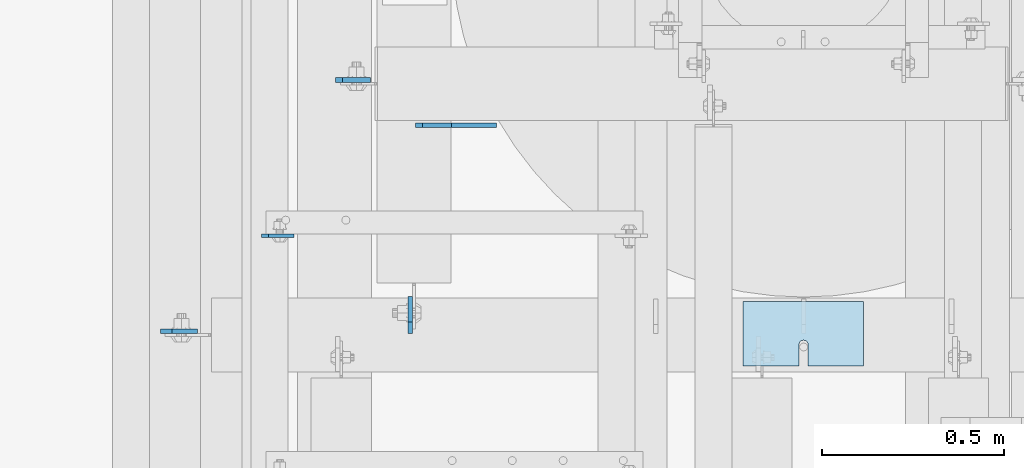
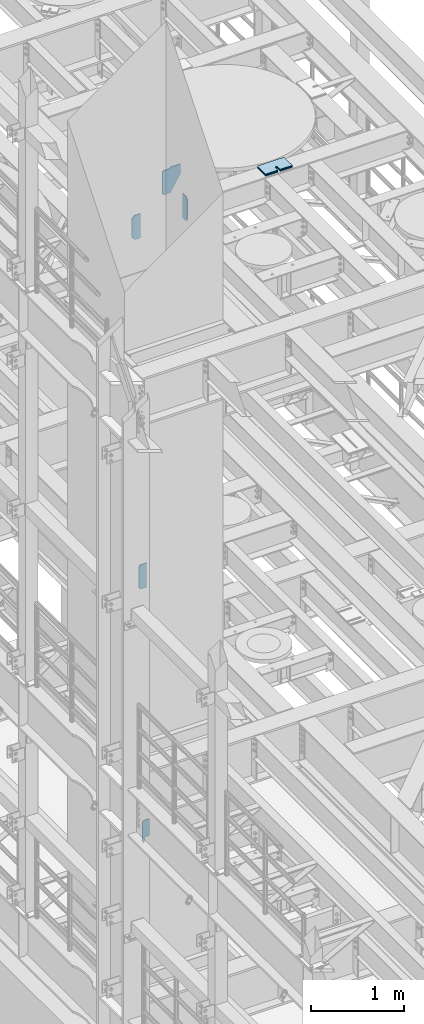
# One storey, part 1626 of 1876: 11 plates, 11 elements without a shape of their own.
"""IFC2X3 building model written with IfcOpenShell, lengths in millimetres."""

from ifc_helpers import new_model, si_unit, frame, origin_with_axes, place, context, subcontext, project, spatial, faceted_brep, material, type_object, element, aggregate, save


model = new_model("IFC2X3")

# Units and contexts
model_context = context("Model", 3, precision=1e-05, world=origin_with_axes())
body_context = subcontext(model_context, "Body", "Model", "MODEL_VIEW")
ifc_project = project(units=[si_unit("LENGTHUNIT", "METRE", prefix="MILLI"), si_unit("AREAUNIT", "SQUARE_METRE"), si_unit("VOLUMEUNIT", "CUBIC_METRE"), si_unit("MASSUNIT", "GRAM", prefix="KILO"), si_unit("TIMEUNIT", "SECOND"), si_unit("PLANEANGLEUNIT", "RADIAN"), si_unit("SOLIDANGLEUNIT", "STERADIAN"), si_unit("THERMODYNAMICTEMPERATUREUNIT", "DEGREE_CELSIUS"), si_unit("LUMINOUSINTENSITYUNIT", "LUMEN")], contexts=[model_context])

# Site, building, storey
site_placement = place(None, origin_with_axes())
site = spatial("IfcSite", under=ifc_project, at=site_placement, CompositionType="ELEMENT")
building_placement = place(site_placement, origin_with_axes())
building = spatial("IfcBuilding", under=site, at=building_placement, Name="Undefined", CompositionType="ELEMENT")
storey_placement = place(building_placement, origin_with_axes())
storey = spatial("IfcBuildingStorey", under=building, at=storey_placement, Name="Undefined", CompositionType="ELEMENT", Elevation=0.0)

# Assembly, plate
assembly_1_placement = place(storey_placement, origin_with_axes())
assembly_1 = element("IfcElementAssembly", 1, at=assembly_1_placement, inside=storey, Name="BEAM", AssemblyPlace="NOTDEFINED", PredefinedType="RIGID_FRAME")
ifc_material = material(Name="STEEL/A36")
plate_type_1 = type_object("IfcPlateType", PredefinedType="NOTDEFINED")
plate_1_placement = place(assembly_1_placement, frame((1882.775, 4376.73659114838, 4833.9375), z_axis=(0.0, 0.0, 1.0), x_axis=(1.0, 0.0, 0.0)))
plate_1 = element("IfcPlate", 2, at=plate_1_placement, type_object=plate_type_1, material=ifc_material, Name="PLATE", context=body_context, shape_type="Brep", body=[
    faceted_brep([(30.5410794447303, -4.76249999999982, 0.0), (30.5448681471291, 4.76249999999982, 0.0), (30.5448681471253, 4.76249999999982, 58.7375017166132), (30.5410794447266, -4.76249999999982, 58.7375017166132), (31.5115981461893, 4.76249999999982, 63.5975812346587), (31.5078094437904, -4.76249999999982, 63.5975812346587), (34.264612264453, 4.76249999999982, 67.7177577028133), (34.2608235620542, -4.76249999999982, 67.7177577028133), (38.3847890585462, 4.76249999999982, 70.4707716032917), (38.3810003561475, -4.76249999999982, 70.4707716032917), (43.2448689610637, 4.76249999999982, 71.4375015258793), (43.2410802586651, -4.76249999999982, 71.4375015258793), (88.8981053933326, -4.76249924578678, 71.4375015258793), (88.9000015258789, 4.76250000000005, 71.4375), (19.0499992370605, -4.76249999999982, 0.0), (0.0, -4.76249999999982, 19.0499992370605), (0.0, 4.76249999999982, 19.0499992370605), (19.0499992370605, 4.76249999999982, 0.0), (0.0, -4.76249999999982, 271.462512969971), (0.0, 4.76249999999982, 271.462512969971), (19.0499992370605, -4.76249999999982, 290.512512207031), (19.0499992370605, 4.76249999999982, 290.512512207031), (88.9000015258789, -4.76249999999982, 290.512512207031), (88.9000015258789, 4.76249999999982, 290.512512207031)], [[[0, 1, 2, 3]], [[3, 2, 4, 5]], [[5, 4, 6, 7]], [[7, 6, 8, 9]], [[9, 8, 10, 11]], [[12, 11, 10, 13]], [[14, 15, 16, 17]], [[15, 18, 19, 16]], [[18, 20, 21, 19]], [[20, 22, 23, 21]], [[23, 22, 12, 13]], [[8, 6, 4, 2, 1, 17, 16, 19, 21, 23, 13, 10]], [[14, 17, 1, 0]], [[22, 20, 18, 15, 14, 0, 3, 5, 7, 9, 11, 12]]]),
])
aggregate(assembly_1, [plate_1])

assembly_2_placement = place(storey_placement, origin_with_axes())
assembly_2 = element("IfcElementAssembly", 3, at=assembly_2_placement, inside=storey, Name="BEAM", AssemblyPlace="NOTDEFINED", PredefinedType="RIGID_FRAME")
plate_type_2 = type_object("IfcPlateType", PredefinedType="NOTDEFINED")
plate_2_placement = place(assembly_2_placement, frame((2086.76875, 4804.56875009537, 7821.6125), z_axis=(0.0, 0.0, 1.0), x_axis=(1.0, 0.0, 0.0)))
plate_2 = element("IfcPlate", 4, at=plate_2_placement, type_object=plate_type_2, material=ifc_material, Name="PLATE", context=body_context, shape_type="Brep", body=[
    faceted_brep([(0.0, -6.35000000000196, 19.0499992370605), (-9.09494701772928e-13, -6.34999999999764, 296.862506866455), (1.81898940354586e-12, 6.34999999999786, 296.862506866455), (0.0, 6.35000000000105, 19.0499992370605), (19.0499992370587, -6.34999999999604, 315.912506103516), (19.0499992370624, 6.34999999999945, 315.912506103516), (95.25, -6.35000000000036, 315.912506103516), (95.25, 6.35000000000036, 315.912506103516), (95.25, -6.35000000000036, 0.0), (95.25, 6.35000000000036, 0.0), (19.0499992370642, -6.35000000000105, 0.0), (19.0499992370633, 6.35000000000105, 0.0)], [[[0, 1, 2, 3]], [[1, 4, 5, 2]], [[4, 6, 7, 5]], [[6, 8, 9, 7]], [[8, 10, 11, 9]], [[10, 0, 3, 11]], [[5, 7, 9, 11, 3, 2]], [[10, 8, 6, 4, 1, 0]]]),
])
aggregate(assembly_2, [plate_2])

assembly_3_placement = place(storey_placement, origin_with_axes())
assembly_3 = element("IfcElementAssembly", 5, at=assembly_3_placement, inside=storey, Name="BEAM", AssemblyPlace="NOTDEFINED", PredefinedType="RIGID_FRAME")
plate_type_3 = type_object("IfcPlateType", PredefinedType="NOTDEFINED")
plate_3_placement = place(assembly_3_placement, frame((1605.75625, 4114.00625009537, 12974.6375), z_axis=(0.0, 0.0, 1.0), x_axis=(1.0, 0.0, 0.0)))
plate_3 = element("IfcPlate", 6, at=plate_3_placement, type_object=plate_type_3, material=ifc_material, Name="PLATE", context=body_context, shape_type="Brep", body=[
    faceted_brep([(0.0, -6.34999999999991, 31.75), (-1.81898940354586e-12, -6.34999999999991, 284.162506103516), (1.81898940354586e-12, 6.35000000000173, 284.162506103516), (0.0, 6.34999999999991, 31.75), (31.7499999999927, -6.34999999999991, 315.912506103516), (31.7499999999982, 6.35000000000309, 315.912506103516), (101.599998474121, -6.35000000000036, 315.912506103516), (101.599998474121, 6.35000000000036, 315.912506103516), (101.599998474121, -6.35000000000036, 0.0), (101.599998474121, 6.35000000000036, 0.0), (31.75, -6.34999999999991, 0.0), (31.75, 6.34999999999991, 0.0)], [[[0, 1, 2, 3]], [[1, 4, 5, 2]], [[4, 6, 7, 5]], [[6, 8, 9, 7]], [[8, 10, 11, 9]], [[10, 0, 3, 11]], [[5, 7, 9, 11, 3, 2]], [[10, 8, 6, 4, 1, 0]]]),
])
aggregate(assembly_3, [plate_3])

assembly_4_placement = place(storey_placement, origin_with_axes())
assembly_4 = element("IfcElementAssembly", 7, at=assembly_4_placement, inside=storey, Name="BEAM", AssemblyPlace="NOTDEFINED", PredefinedType="RIGID_FRAME")
plate_4_placement = place(assembly_4_placement, frame((2291.55624990463, 4107.65625, 12977.8125), z_axis=(0.0, 0.0, 1.0), x_axis=(0.0, 1.0, 0.0)))
plate_4 = element("IfcPlate", 8, at=plate_4_placement, type_object=plate_type_3, material=ifc_material, Name="PLATE", context=body_context, shape_type="Brep", body=[
    faceted_brep([(0.0, -6.34999999999991, 31.75), (-1.81898940354586e-12, -6.34999999999991, 284.162506103516), (1.81898940354586e-12, 6.35000000000173, 284.162506103516), (0.0, 6.34999999999991, 31.75), (31.7499999999927, -6.34999999999991, 315.912506103516), (31.7499999999982, 6.35000000000309, 315.912506103516), (101.599998474121, -6.35000000000036, 315.912506103516), (101.599998474121, 6.35000000000036, 315.912506103516), (101.599998474121, -6.35000000000036, 0.0), (101.599998474121, 6.35000000000036, 0.0), (31.75, -6.34999999999991, 0.0), (31.75, 6.34999999999991, 0.0)], [[[0, 1, 2, 3]], [[1, 4, 5, 2]], [[4, 6, 7, 5]], [[6, 8, 9, 7]], [[8, 10, 11, 9]], [[10, 0, 3, 11]], [[5, 7, 9, 11, 3, 2]], [[10, 8, 6, 4, 1, 0]]]),
])
aggregate(assembly_4, [plate_4])

assembly_5_placement = place(storey_placement, origin_with_axes())
assembly_5 = element("IfcElementAssembly", 9, at=assembly_5_placement, inside=storey, Name="SHIM PLATE", AssemblyPlace="NOTDEFINED", PredefinedType="RIGID_FRAME")
plate_type_4 = type_object("IfcPlateType", PredefinedType="NOTDEFINED")
plate_5_placement = place(assembly_5_placement, frame((3205.99836578369, 4196.45223303297, 13335.7925), z_axis=(1.0, 0.0, 0.0), x_axis=(0.0, -1.0, 0.0)))
plate_5 = element("IfcPlate", 10, at=plate_5_placement, type_object=plate_type_4, material=ifc_material, Name="SHIM PLATE", context=body_context, shape_type="Brep", body=[
    faceted_brep([(177.654449462891, -0.793499999999767, 153.152024232435), (177.654449462891, 0.793499999999767, 153.152024232435), (118.915740966797, 0.793499999999767, 153.152024232435), (118.915740966797, -0.793499999999767, 153.152024232435), (112.565739046814, 0.793499999999767, 154.853499989362), (112.565739046814, -0.793499999999767, 154.853499989362), (107.917214530273, 0.793499999999767, 159.502022760557), (107.917214530273, -0.793499999999767, 159.502022760557), (106.21573638916, 0.793499999999767, 165.8520240417), (106.21573638916, -0.793499999999767, 165.8520240417), (107.917214530273, 0.793499999999767, 172.202025322844), (107.917214530273, -0.793499999999767, 172.202025322844), (112.565739046813, 0.793499999999767, 176.850548094039), (112.565739046813, -0.793499999999767, 176.850548094039), (118.915740966797, 0.793499999999767, 178.552023850965), (118.915740966797, -0.793499999999767, 178.552023850965), (177.654449462891, -0.793499999999767, 178.552023850965), (177.654449462891, 0.793499999999767, 178.552023850965), (177.654449462891, -0.793499999999767, 0.0), (9.09494701772928e-13, -0.793499999999767, 0.0), (9.09494701772928e-13, 0.793499999999767, 0.0), (177.654449462891, 0.793499999999767, 0.0), (0.0, -0.793499999999767, 330.201965332031), (0.0, 0.793499999999767, 330.201965332031), (177.654449462891, -0.793499999999767, 330.201965332031), (177.654449462891, 0.793499999999767, 330.201965332031)], [[[0, 1, 2, 3]], [[3, 2, 4, 5]], [[5, 4, 6, 7]], [[7, 6, 8, 9]], [[9, 8, 10, 11]], [[11, 10, 12, 13]], [[13, 12, 14, 15]], [[16, 15, 14, 17]], [[18, 19, 20, 21]], [[19, 22, 23, 20]], [[22, 24, 25, 23]], [[25, 24, 16, 17]], [[12, 10, 8, 6, 4, 2, 1, 21, 20, 23, 25, 17, 14]], [[18, 21, 1, 0]], [[24, 22, 19, 18, 0, 3, 5, 7, 9, 11, 13, 15, 16]]]),
])
aggregate(assembly_5, [plate_5])

assembly_6_placement = place(storey_placement, origin_with_axes())
assembly_6 = element("IfcElementAssembly", 11, at=assembly_6_placement, inside=storey, Name="SHIM PLATE", AssemblyPlace="NOTDEFINED", PredefinedType="RIGID_FRAME")
plate_type_5 = type_object("IfcPlateType", PredefinedType="NOTDEFINED")
plate_6_placement = place(assembly_6_placement, frame((3205.99836578369, 4196.45223303297, 13333.4115), z_axis=(1.0, 0.0, 0.0), x_axis=(0.0, -1.0, 0.0)))
plate_6 = element("IfcPlate", 12, at=plate_6_placement, type_object=plate_type_5, material=ifc_material, Name="SHIM PLATE", context=body_context, shape_type="Brep", body=[
    faceted_brep([(177.654449462891, -1.58749999999964, 153.152024232435), (177.654449462891, 1.58749999999964, 153.152024232435), (118.915740966797, 1.58749999999964, 153.152024232435), (118.915740966797, -1.58749999999964, 153.152024232435), (112.565739046814, 1.58749999999964, 154.853499989362), (112.565739046814, -1.58749999999964, 154.853499989362), (107.917214530273, 1.58749999999964, 159.502022760557), (107.917214530273, -1.58749999999964, 159.502022760557), (106.21573638916, 1.58749999999964, 165.8520240417), (106.21573638916, -1.58749999999964, 165.8520240417), (107.917214530273, 1.58749999999964, 172.202025322844), (107.917214530273, -1.58749999999964, 172.202025322844), (112.565739046813, 1.58749999999964, 176.850548094039), (112.565739046813, -1.58749999999964, 176.850548094039), (118.915740966797, 1.58749999999964, 178.552023850965), (118.915740966797, -1.58749999999964, 178.552023850965), (177.654449462891, -1.58749999999964, 178.552023850965), (177.654449462891, 1.58749999999964, 178.552023850965), (177.654449462891, -1.58749999999964, 0.0), (9.09494701772928e-13, -1.58750000000146, 4.54747350886464e-13), (9.09494701772928e-13, 1.58750000000146, 4.54747350886464e-13), (177.654449462891, 1.58749999999964, 0.0), (0.0, -1.58749999999964, 330.201965332031), (0.0, 1.58749999999964, 330.201965332031), (177.654449462891, -1.58749999999964, 330.201965332031), (177.654449462891, 1.58749999999964, 330.201965332031)], [[[0, 1, 2, 3]], [[3, 2, 4, 5]], [[5, 4, 6, 7]], [[7, 6, 8, 9]], [[9, 8, 10, 11]], [[11, 10, 12, 13]], [[13, 12, 14, 15]], [[16, 15, 14, 17]], [[18, 19, 20, 21]], [[19, 22, 23, 20]], [[22, 24, 25, 23]], [[25, 24, 16, 17]], [[12, 10, 8, 6, 4, 2, 1, 21, 20, 23, 25, 17, 14]], [[18, 21, 1, 0]], [[24, 22, 19, 18, 0, 3, 5, 7, 9, 11, 13, 15, 16]]]),
])
aggregate(assembly_6, [plate_6])

assembly_7_placement = place(storey_placement, origin_with_axes())
assembly_7 = element("IfcElementAssembly", 13, at=assembly_7_placement, inside=storey, Name="SHIM PLATE", AssemblyPlace="NOTDEFINED", PredefinedType="RIGID_FRAME")
plate_7_placement = place(assembly_7_placement, frame((3205.99836578369, 4196.45223303297, 13330.2365), z_axis=(1.0, 0.0, 0.0), x_axis=(0.0, -1.0, 0.0)))
plate_7 = element("IfcPlate", 14, at=plate_7_placement, type_object=plate_type_5, material=ifc_material, Name="SHIM PLATE", context=body_context, shape_type="Brep", body=[
    faceted_brep([(177.654449462891, -1.58749999999964, 153.152024232435), (177.654449462891, 1.58749999999964, 153.152024232435), (118.915740966797, 1.58749999999964, 153.152024232435), (118.915740966797, -1.58749999999964, 153.152024232435), (112.565739046814, 1.58749999999964, 154.853499989362), (112.565739046814, -1.58749999999964, 154.853499989362), (107.917214530273, 1.58749999999964, 159.502022760557), (107.917214530273, -1.58749999999964, 159.502022760557), (106.21573638916, 1.58749999999964, 165.8520240417), (106.21573638916, -1.58749999999964, 165.8520240417), (107.917214530273, 1.58749999999964, 172.202025322844), (107.917214530273, -1.58749999999964, 172.202025322844), (112.565739046813, 1.58749999999964, 176.850548094039), (112.565739046813, -1.58749999999964, 176.850548094039), (118.915740966797, 1.58749999999964, 178.552023850965), (118.915740966797, -1.58749999999964, 178.552023850965), (177.654449462891, -1.58749999999964, 178.552023850965), (177.654449462891, 1.58749999999964, 178.552023850965), (177.654449462891, -1.58749999999964, 0.0), (9.09494701772928e-13, -1.58750000000146, 4.54747350886464e-13), (9.09494701772928e-13, 1.58750000000146, 4.54747350886464e-13), (177.654449462891, 1.58749999999964, 0.0), (0.0, -1.58749999999964, 330.201965332031), (0.0, 1.58749999999964, 330.201965332031), (177.654449462891, -1.58749999999964, 330.201965332031), (177.654449462891, 1.58749999999964, 330.201965332031)], [[[0, 1, 2, 3]], [[3, 2, 4, 5]], [[5, 4, 6, 7]], [[7, 6, 8, 9]], [[9, 8, 10, 11]], [[11, 10, 12, 13]], [[13, 12, 14, 15]], [[16, 15, 14, 17]], [[18, 19, 20, 21]], [[19, 22, 23, 20]], [[22, 24, 25, 23]], [[25, 24, 16, 17]], [[12, 10, 8, 6, 4, 2, 1, 21, 20, 23, 25, 17, 14]], [[18, 21, 1, 0]], [[24, 22, 19, 18, 0, 3, 5, 7, 9, 11, 13, 15, 16]]]),
])
aggregate(assembly_7, [plate_7])

assembly_8_placement = place(storey_placement, origin_with_axes())
assembly_8 = element("IfcElementAssembly", 15, at=assembly_8_placement, inside=storey, Name="SHIM PLATE", AssemblyPlace="NOTDEFINED", PredefinedType="RIGID_FRAME")
plate_type_6 = type_object("IfcPlateType", PredefinedType="NOTDEFINED")
plate_8_placement = place(assembly_8_placement, frame((3205.99836578369, 4196.45223303297, 13326.268), z_axis=(1.0, 0.0, 0.0), x_axis=(0.0, -1.0, 0.0)))
plate_8 = element("IfcPlate", 16, at=plate_8_placement, type_object=plate_type_6, material=ifc_material, Name="SHIM PLATE", context=body_context, shape_type="Brep", body=[
    faceted_brep([(177.654449462891, -2.3809999999994, 153.152024232435), (177.654449462891, 2.3809999999994, 153.152024232435), (118.915740966797, 2.3809999999994, 153.152024232435), (118.915740966797, -2.3809999999994, 153.152024232435), (112.565739046814, 2.3809999999994, 154.853499989362), (112.565739046814, -2.3809999999994, 154.853499989362), (107.917214530273, 2.3809999999994, 159.502022760557), (107.917214530273, -2.3809999999994, 159.502022760557), (106.21573638916, 2.3809999999994, 165.8520240417), (106.21573638916, -2.3809999999994, 165.8520240417), (107.917214530273, 2.3809999999994, 172.202025322844), (107.917214530273, -2.3809999999994, 172.202025322844), (112.565739046813, 2.3809999999994, 176.850548094039), (112.565739046813, -2.3809999999994, 176.850548094039), (118.915740966797, 2.3809999999994, 178.552023850965), (118.915740966797, -2.3809999999994, 178.552023850965), (177.654449462891, -2.3809999999994, 178.552023850965), (177.654449462891, 2.3809999999994, 178.552023850965), (177.654449462891, -2.3809999999994, 0.0), (0.0, -2.38100000000122, 4.54747350886464e-13), (0.0, 2.38100000000122, 4.54747350886464e-13), (177.654449462891, 2.3809999999994, 0.0), (0.0, -2.3809999999994, 330.201965332031), (0.0, 2.3809999999994, 330.201965332031), (177.654449462891, -2.3809999999994, 330.201965332031), (177.654449462891, 2.3809999999994, 330.201965332031)], [[[0, 1, 2, 3]], [[3, 2, 4, 5]], [[5, 4, 6, 7]], [[7, 6, 8, 9]], [[9, 8, 10, 11]], [[11, 10, 12, 13]], [[13, 12, 14, 15]], [[16, 15, 14, 17]], [[18, 19, 20, 21]], [[19, 22, 23, 20]], [[22, 24, 25, 23]], [[25, 24, 16, 17]], [[12, 10, 8, 6, 4, 2, 1, 21, 20, 23, 25, 17, 14]], [[18, 21, 1, 0]], [[24, 22, 19, 18, 0, 3, 5, 7, 9, 11, 13, 15, 16]]]),
])
aggregate(assembly_8, [plate_8])

assembly_9_placement = place(storey_placement, origin_with_axes())
assembly_9 = element("IfcElementAssembly", 17, at=assembly_9_placement, inside=storey, Name="SHIM PLATE", AssemblyPlace="NOTDEFINED", PredefinedType="RIGID_FRAME")
plate_9_placement = place(assembly_9_placement, frame((3205.99836578369, 4196.45223303297, 13321.506), z_axis=(1.0, 0.0, 0.0), x_axis=(0.0, -1.0, 0.0)))
plate_9 = element("IfcPlate", 18, at=plate_9_placement, type_object=plate_type_6, material=ifc_material, Name="SHIM PLATE", context=body_context, shape_type="Brep", body=[
    faceted_brep([(177.654449462891, -2.3809999999994, 153.152024232435), (177.654449462891, 2.3809999999994, 153.152024232435), (118.915740966797, 2.3809999999994, 153.152024232435), (118.915740966797, -2.3809999999994, 153.152024232435), (112.565739046814, 2.3809999999994, 154.853499989362), (112.565739046814, -2.3809999999994, 154.853499989362), (107.917214530273, 2.3809999999994, 159.502022760557), (107.917214530273, -2.3809999999994, 159.502022760557), (106.21573638916, 2.3809999999994, 165.8520240417), (106.21573638916, -2.3809999999994, 165.8520240417), (107.917214530273, 2.3809999999994, 172.202025322844), (107.917214530273, -2.3809999999994, 172.202025322844), (112.565739046813, 2.3809999999994, 176.850548094039), (112.565739046813, -2.3809999999994, 176.850548094039), (118.915740966797, 2.3809999999994, 178.552023850965), (118.915740966797, -2.3809999999994, 178.552023850965), (177.654449462891, -2.3809999999994, 178.552023850965), (177.654449462891, 2.3809999999994, 178.552023850965), (177.654449462891, -2.3809999999994, 0.0), (0.0, -2.38100000000122, 4.54747350886464e-13), (0.0, 2.38100000000122, 4.54747350886464e-13), (177.654449462891, 2.3809999999994, 0.0), (0.0, -2.3809999999994, 330.201965332031), (0.0, 2.3809999999994, 330.201965332031), (177.654449462891, -2.3809999999994, 330.201965332031), (177.654449462891, 2.3809999999994, 330.201965332031)], [[[0, 1, 2, 3]], [[3, 2, 4, 5]], [[5, 4, 6, 7]], [[7, 6, 8, 9]], [[9, 8, 10, 11]], [[11, 10, 12, 13]], [[13, 12, 14, 15]], [[16, 15, 14, 17]], [[18, 19, 20, 21]], [[19, 22, 23, 20]], [[22, 24, 25, 23]], [[25, 24, 16, 17]], [[12, 10, 8, 6, 4, 2, 1, 21, 20, 23, 25, 17, 14]], [[18, 21, 1, 0]], [[24, 22, 19, 18, 0, 3, 5, 7, 9, 11, 13, 15, 16]]]),
])
aggregate(assembly_9, [plate_9])

assembly_10_placement = place(storey_placement, origin_with_axes())
assembly_10 = element("IfcElementAssembly", 19, at=assembly_10_placement, inside=storey, Name="SHIM PLATE", AssemblyPlace="NOTDEFINED", PredefinedType="RIGID_FRAME")
plate_type_7 = type_object("IfcPlateType", PredefinedType="NOTDEFINED")
plate_10_placement = place(assembly_10_placement, frame((3205.99836578369, 4196.45223303297, 13314.3625), z_axis=(1.0, 0.0, 0.0), x_axis=(0.0, -1.0, 0.0)))
plate_10 = element("IfcPlate", 20, at=plate_10_placement, type_object=plate_type_7, material=ifc_material, Name="SHIM PLATE", context=body_context, shape_type="Brep", body=[
    faceted_brep([(177.654449462891, -4.76250000000073, 153.152024232435), (177.654449462891, 4.76250000000073, 153.152024232435), (118.915740966797, 4.76250000000073, 153.152024232435), (118.915740966797, -4.76250000000073, 153.152024232435), (112.565739046814, 4.76250000000073, 154.853499989362), (112.565739046814, -4.76250000000073, 154.853499989362), (107.917214530273, 4.76250000000073, 159.502022760557), (107.917214530273, -4.76250000000073, 159.502022760557), (106.21573638916, 4.76250000000073, 165.8520240417), (106.21573638916, -4.76250000000073, 165.8520240417), (107.917214530273, 4.76250000000073, 172.202025322844), (107.917214530273, -4.76250000000073, 172.202025322844), (112.565739046813, 4.76250000000073, 176.850548094039), (112.565739046813, -4.76250000000073, 176.850548094039), (118.915740966797, 4.76250000000073, 178.552023850965), (118.915740966797, -4.76250000000073, 178.552023850965), (177.654449462891, -4.76250000000073, 178.552023850965), (177.654449462891, 4.76250000000073, 178.552023850965), (177.654449462891, -4.76250000000073, 0.0), (0.0, -4.76249999999982, 0.0), (0.0, 4.76249999999982, 0.0), (177.654449462891, 4.76250000000073, 0.0), (0.0, -4.76250000000073, 330.201965332031), (0.0, 4.76250000000073, 330.201965332031), (177.654449462891, -4.76250000000073, 330.201965332031), (177.654449462891, 4.76250000000073, 330.201965332031)], [[[0, 1, 2, 3]], [[3, 2, 4, 5]], [[5, 4, 6, 7]], [[7, 6, 8, 9]], [[9, 8, 10, 11]], [[11, 10, 12, 13]], [[13, 12, 14, 15]], [[16, 15, 14, 17]], [[18, 19, 20, 21]], [[19, 22, 23, 20]], [[22, 24, 25, 23]], [[25, 24, 16, 17]], [[12, 10, 8, 6, 4, 2, 1, 21, 20, 23, 25, 17, 14]], [[18, 21, 1, 0]], [[24, 22, 19, 18, 0, 3, 5, 7, 9, 11, 13, 15, 16]]]),
])
aggregate(assembly_10, [plate_10])

assembly_11_placement = place(storey_placement, origin_with_axes())
assembly_11 = element("IfcElementAssembly", 21, at=assembly_11_placement, inside=storey, Name="BEAM", AssemblyPlace="NOTDEFINED", PredefinedType="RIGID_FRAME")
plate_type_8 = type_object("IfcPlateType", PredefinedType="NOTDEFINED")
plate_11_placement = place(assembly_11_placement, frame((2403.47499866946, 4679.9499993653, 12976.2250305176), z_axis=(0.0, 0.0, 1.0), x_axis=(-1.0, 0.0, 0.0)))
plate_11 = element("IfcPlate", 22, at=plate_11_placement, type_object=plate_type_8, material=ifc_material, Name="PLATE", context=body_context, shape_type="Brep", body=[
    faceted_brep([(0.0, -6.35000000000036, 0.0), (-124.618827819858, -6.3499999999076, 206.374938964955), (-124.618827819858, 6.35000000009222, 206.374938964949), (0.0, 6.35000000000036, 0.0), (-124.619010925342, -6.34999999985121, 333.374969482538), (-124.619010925342, 6.35000000014861, 333.374969482533), (-1.58718562130525, -6.34999999985121, 333.374969482444), (-1.58718562130525, 6.35000000014861, 333.374969482438), (-1.58756351473312, -6.35000000001992, 317.499969482458), (-1.58756351473858, 6.34999999998013, 317.499969482449), (78.5811500548944, -6.34999999985939, 317.499994140582), (78.5811500548944, 6.35000000014134, 317.499994140577), (97.6311552428851, -6.34999999986758, 298.450000762883), (97.6311552428851, 6.35000000013315, 298.450000762878), (97.6312425231954, -6.34999999999218, 19.049999237006), (97.6312425231954, 6.35000000000855, 19.0499992370005), (78.5812492370633, -6.35000000000036, -4.18367562815547e-11), (78.5812492370633, 6.35000000000036, -4.72937244921923e-11)], [[[0, 1, 2, 3]], [[1, 4, 5, 2]], [[4, 6, 7, 5]], [[6, 8, 9, 7]], [[8, 10, 11, 9]], [[10, 12, 13, 11]], [[12, 14, 15, 13]], [[14, 16, 17, 15]], [[16, 0, 3, 17]], [[5, 7, 9, 11, 13, 15, 17, 3, 2]], [[16, 14, 12, 10, 8, 6, 4, 1, 0]]]),
])
aggregate(assembly_11, [plate_11])

save(model, "model.ifc")
